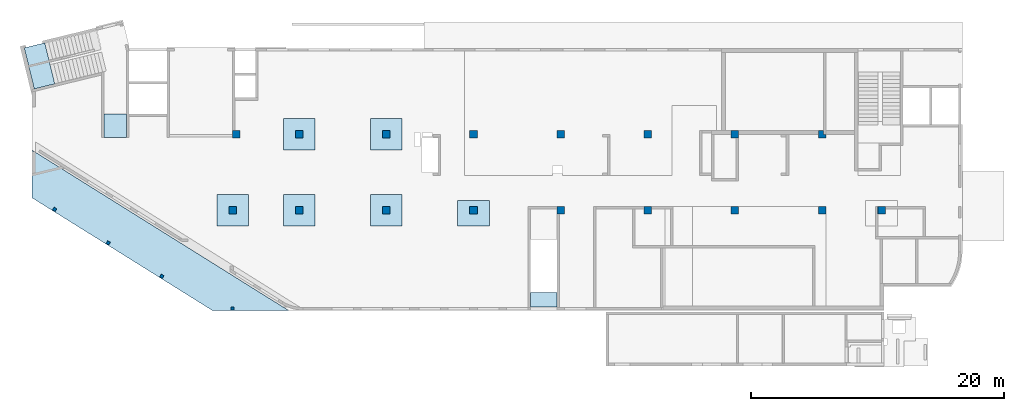
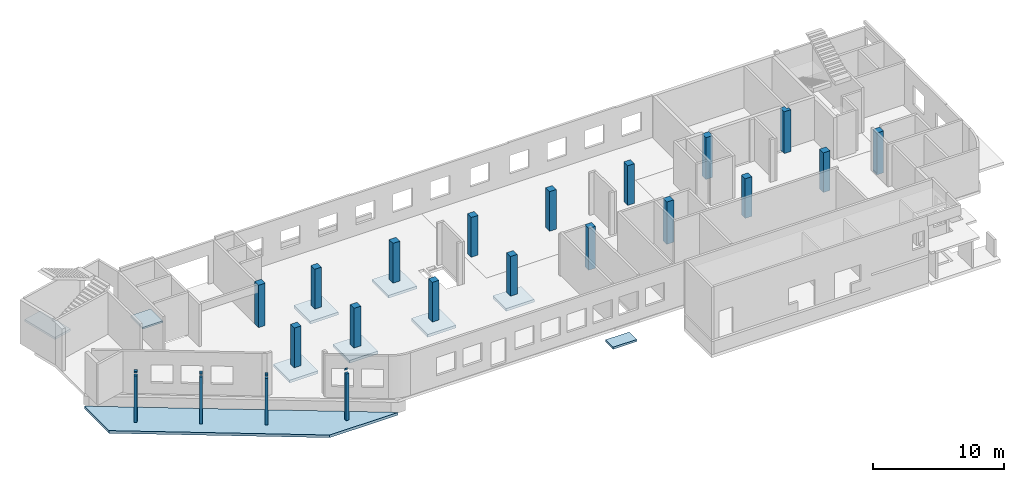
# One storey, part 1 of 8: 21 columns, 10 slabs.
"""IFC4 building model written with IfcOpenShell, lengths in millimetres."""

import ifcopenshell
import ifcopenshell.guid

model = None  # the IFC model being written
_history = None  # IfcOwnerHistory: only IFC2X3 demands one
_inside = {}  # id of a spatial element -> (the spatial element, [elements in it])
_under = {}  # id of a project, library or spatial element -> (it, [spatial elements below it])
_declared = {}  # id of a project -> (the project, [libraries it declares])
_typed = {}  # id of a type object -> (the type object, [elements of that type])
_made_of = {}  # id of a material, layer set ... -> (it, [elements and type objects made of it])


def new_model(schema):
    """Start an empty IFC model of exactly this schema.

    Asked for "IFC4X3", IfcOpenShell would pick the latest addendum, in which some entities
    have other attributes; the version numbers below select the first issue.
    IFC2X3 requires an IfcOwnerHistory on every rooted entity: one is made here for all.
    """
    global model, _history
    if schema == "IFC4X3":
        model = ifcopenshell.file(schema_version=(4, 3, 0, 0))
    else:
        model = ifcopenshell.file(schema=schema)
    _inside.clear()
    _under.clear()
    _declared.clear()
    _typed.clear()
    _made_of.clear()
    _history = None
    if model.schema == "IFC2X3":
        org = make("IfcOrganization", Name="unknown")
        user = make(
            "IfcPersonAndOrganization",
            ThePerson=make("IfcPerson", FamilyName="unknown"),
            TheOrganization=org,
        )
        app = make(
            "IfcApplication",
            ApplicationDeveloper=org,
            Version="unknown",
            ApplicationFullName="unknown",
            ApplicationIdentifier="unknown",
        )
        _history = make(
            "IfcOwnerHistory",
            OwningUser=user,
            OwningApplication=app,
            ChangeAction="ADDED",
            CreationDate=0,
        )
    return model


def make(cls, **values):
    """One entity of the class cls with the attributes given. An attribute that is None is left unset."""
    return model.create_entity(
        cls, **{name: value for name, value in values.items() if value is not None}
    )


def entity(cls, *values):
    """Any entity or typed value of the class cls, its attributes in the order of the schema. None: left unset."""
    e = model.create_entity(cls)
    for i, value in enumerate(values):
        if value is not None:
            e[i] = value
    return e


def rooted(cls, **values):
    """An entity with a GlobalId (a new one), such as an element, a storey or a relation."""
    return make(cls, GlobalId=ifcopenshell.guid.new(), OwnerHistory=_history, **values)


def si_unit(unit_type, name, prefix=None):
    """IfcSIUnit, for example si_unit("LENGTHUNIT", "METRE", prefix="MILLI")."""
    return make("IfcSIUnit", UnitType=unit_type, Prefix=prefix, Name=name)


def converted_unit(unit_type, name, factor, base, dimensions=None, offset=None):
    """IfcConversionBasedUnit, such as the inch: factor (a typed value) times the base unit."""
    return make(
        "IfcConversionBasedUnit"
        if offset is None
        else "IfcConversionBasedUnitWithOffset",
        ConversionOffset=offset,
        Dimensions=None
        if dimensions is None
        else entity("IfcDimensionalExponents", *dimensions),
        UnitType=unit_type,
        Name=name,
        ConversionFactor=make(
            "IfcMeasureWithUnit", ValueComponent=factor, UnitComponent=base
        ),
    )


def derived_unit(unit_type, elements):
    """IfcDerivedUnit: a product of units, each with its exponent."""
    return make(
        "IfcDerivedUnit",
        Elements=[
            make("IfcDerivedUnitElement", Unit=unit, Exponent=power)
            for unit, power in elements
        ],
        UnitType=unit_type,
    )


def assignment(units):
    """IfcUnitAssignment: the units of a project."""
    return None if units is None else make("IfcUnitAssignment", Units=units)


def point(xyz):
    """IfcCartesianPoint."""
    return None if xyz is None else make("IfcCartesianPoint", Coordinates=xyz)


def direction(xyz):
    """IfcDirection."""
    return None if xyz is None else make("IfcDirection", DirectionRatios=xyz)


def frame(location, z_axis=None, x_axis=None):
    """IfcAxis2Placement3D, a coordinate frame: its origin and axes. An axis left out is left unset."""
    return make(
        "IfcAxis2Placement3D",
        Location=point(location),
        Axis=direction(z_axis),
        RefDirection=direction(x_axis),
    )


def origin():
    """The frame at (0, 0, 0) with its axes left unset."""
    return frame((0.0, 0.0, 0.0))


def place(relative_to, where):
    """IfcLocalPlacement: puts the frame where relative to a parent placement (None: the world)."""
    return make(
        "IfcLocalPlacement", PlacementRelTo=relative_to, RelativePlacement=where
    )


def context(
    kind, dimensions, precision=None, world=None, true_north=None, identifier=None
):
    """IfcGeometricRepresentationContext, for example the 3D "Model" context."""
    return make(
        "IfcGeometricRepresentationContext",
        ContextIdentifier=identifier,
        ContextType=kind,
        CoordinateSpaceDimension=dimensions,
        Precision=precision,
        WorldCoordinateSystem=world,
        TrueNorth=true_north,
    )


def subcontext(parent, identifier, kind, view, scale=None):
    """IfcGeometricRepresentationSubContext, for example "Body" below "Model"."""
    return make(
        "IfcGeometricRepresentationSubContext",
        ContextIdentifier=identifier,
        ContextType=kind,
        ParentContext=parent,
        TargetScale=scale,
        TargetView=view,
    )


def project(units=None, contexts=None):
    """IfcProject with its units and contexts."""
    return rooted(
        "IfcProject",
        Name="project",
        RepresentationContexts=contexts,
        UnitsInContext=assignment(units),
    )


def spatial(cls, under=None, at=None, **own):
    """A site, building, storey or space (cls), placed at a placement, below another one or the project."""
    s = rooted(cls, ObjectPlacement=at, **own)
    if under is not None:
        _under.setdefault(under.id(), (under, []))[1].append(s)
    return s


def point_list(points):
    """IfcCartesianPointList2D or 3D."""
    cls = (
        "IfcCartesianPointList2D" if len(points[0]) == 2 else "IfcCartesianPointList3D"
    )
    return make(cls, CoordList=points)


def indexed_curve(points, segments=None, self_intersect=None):
    """IfcIndexedPolyCurve: lines and arcs through numbered points (the first is 1)."""
    return make(
        "IfcIndexedPolyCurve",
        Points=point_list(points),
        Segments=segments,
        SelfIntersect=self_intersect,
    )


def outline(outer, holes=None, kind="AREA"):
    """IfcArbitraryClosedProfileDef: a profile drawn as a closed curve; with holes, ...WithVoids."""
    if holes is None:
        return make("IfcArbitraryClosedProfileDef", ProfileType=kind, OuterCurve=outer)
    return make(
        "IfcArbitraryProfileDefWithVoids",
        ProfileType=kind,
        OuterCurve=outer,
        InnerCurves=holes,
    )


def extrude(swept, where, along, depth):
    """IfcExtrudedAreaSolid: the profile swept, set in the frame where, extruded along a direction by depth."""
    return make(
        "IfcExtrudedAreaSolid",
        SweptArea=swept,
        Position=where,
        ExtrudedDirection=direction(along),
        Depth=depth,
    )


def polygons(points, faces, closed=None, point_numbers=None):
    """IfcPolygonalFaceSet: a face is its outer loop, then its inner loops; points numbered from 1."""
    made = []
    for loops in faces:
        if len(loops) == 1:
            made.append(make("IfcIndexedPolygonalFace", CoordIndex=loops[0]))
        else:
            made.append(
                make(
                    "IfcIndexedPolygonalFaceWithVoids",
                    CoordIndex=loops[0],
                    InnerCoordIndices=loops[1:],
                )
            )
    return make(
        "IfcPolygonalFaceSet",
        Coordinates=point_list(points),
        Closed=closed,
        Faces=made,
        PnIndex=point_numbers,
    )


def shape(context_of_items, identifier, shape_type, items):
    """IfcShapeRepresentation: the items that make up one representation, for example the "Body"."""
    return make(
        "IfcShapeRepresentation",
        ContextOfItems=context_of_items,
        RepresentationIdentifier=identifier,
        RepresentationType=shape_type,
        Items=items,
    )


def source(mapping_origin, context_of_items, identifier, shape_type, items):
    """IfcRepresentationMap: a shape defined once, which mapped items show again and again."""
    return make(
        "IfcRepresentationMap",
        MappingOrigin=mapping_origin,
        MappedRepresentation=shape(context_of_items, identifier, shape_type, items),
    )


def transform(
    local_origin,
    x_axis=None,
    y_axis=None,
    z_axis=None,
    scale=None,
    scale2=None,
    scale3=None,
    uniform=True,
):
    """IfcCartesianTransformationOperator3D, or its non-uniform kind. x_axis, y_axis, z_axis: its Axis1, 2, 3."""
    if uniform:
        return make(
            "IfcCartesianTransformationOperator3D",
            Axis1=direction(x_axis),
            Axis2=direction(y_axis),
            LocalOrigin=point(local_origin),
            Scale=scale,
            Axis3=direction(z_axis),
        )
    return make(
        "IfcCartesianTransformationOperator3DnonUniform",
        Axis1=direction(x_axis),
        Axis2=direction(y_axis),
        LocalOrigin=point(local_origin),
        Scale=scale,
        Axis3=direction(z_axis),
        Scale2=scale2,
        Scale3=scale3,
    )


def mapped(mapping_source, mapping_target):
    """IfcMappedItem: shows the shape of a source again, moved by a transform."""
    return make(
        "IfcMappedItem", MappingSource=mapping_source, MappingTarget=mapping_target
    )


def material(Name=None, Category=None):
    """IfcMaterial."""
    return make("IfcMaterial", Name=Name, Category=Category)


def made_of(thing, what):
    """Note that an element or type object is made of a material, layer set ...; save() writes the relation."""
    if what is not None:
        _made_of.setdefault(what.id(), (what, []))[1].append(thing)
    return thing


def type_object(cls, material=None, **own):
    """A type object (cls), such as IfcWallType, which elements share."""
    return made_of(rooted(cls, **own), material)


def type_shapes(of_type, sources):
    """Give a type object the sources (RepresentationMaps) that its elements show as mapped items."""
    of_type.RepresentationMaps = sources


def element(
    cls,
    number,
    at=None,
    inside=None,
    cuts=None,
    type_object=None,
    material=None,
    context=None,
    identifier="Body",
    shape_type=None,
    held_by="IfcProductDefinitionShape",
    body=None,
    shapes=None,
    **own,
):
    """One element of the class cls, such as IfcWall. Its Tag is "e" and its number.

    at: its placement. inside: the storey or other place that contains it. cuts: it is an
    opening in that element (IfcRelVoidsElement). A single representation is given by context,
    identifier, shape_type and body (its items); several are given by shapes. held_by: the class
    of the entity that holds the representations. save() writes the other relations.
    """
    e = rooted(cls, Tag="e%d" % number, ObjectPlacement=at, **own)
    if body is not None:
        shapes = [shape(context, identifier, shape_type, body)]
    if shapes is not None:
        e.Representation = make(held_by, Representations=shapes)
    if inside is not None:
        _inside.setdefault(inside.id(), (inside, []))[1].append(e)
    if cuts is not None:
        rooted(
            "IfcRelVoidsElement", RelatingBuildingElement=cuts, RelatedOpeningElement=e
        )
    if type_object is not None:
        _typed.setdefault(type_object.id(), (type_object, []))[1].append(e)
    return made_of(e, material)


def aggregate(whole, parts):
    """IfcRelAggregates: a whole, such as a stair, and the parts it consists of."""
    return rooted("IfcRelAggregates", RelatingObject=whole, RelatedObjects=parts)


def save(model, path):
    """Write the relations noted so far, then the file.

    IfcRelAggregates (storeys below a building ...), IfcRelContainedInSpatialStructure (elements
    in a storey), IfcRelDefinesByType, IfcRelAssociatesMaterial and IfcRelDeclares: one each for
    every whole, place, type object, material and project.
    """
    for whole, parts in _under.values():
        aggregate(whole, parts)
    for where, things in _inside.values():
        rooted(
            "IfcRelContainedInSpatialStructure",
            RelatedElements=things,
            RelatingStructure=where,
        )
    for kind, things in _typed.values():
        rooted("IfcRelDefinesByType", RelatedObjects=things, RelatingType=kind)
    for what, things in _made_of.values():
        rooted("IfcRelAssociatesMaterial", RelatedObjects=things, RelatingMaterial=what)
    for by, libraries in _declared.values():
        rooted("IfcRelDeclares", RelatingContext=by, RelatedDefinitions=libraries)
    model.write(path)


model = new_model("IFC4")

# Units and contexts
model_context = context("Model", 3, precision=0.01, world=origin(), true_north=direction((6.12303176911189e-17, 1.0)))
plan_context = context("Plan", 3, precision=0.01, world=origin(), true_north=direction((6.12303176911189e-17, 1.0)))
body_context = subcontext(model_context, "Body", "Model", "MODEL_VIEW")
ifc_project = project(units=[si_unit("LENGTHUNIT", "METRE", prefix="MILLI"), si_unit("AREAUNIT", "SQUARE_METRE"), si_unit("VOLUMEUNIT", "CUBIC_METRE"), converted_unit("PLANEANGLEUNIT", "DEGREE", entity("IfcRatioMeasure", 0.0174532925199433), si_unit("PLANEANGLEUNIT", "RADIAN"), dimensions=[0, 0, 0, 0, 0, 0, 0]), si_unit("MASSUNIT", "GRAM", prefix="KILO"), derived_unit("MASSDENSITYUNIT", [(si_unit("MASSUNIT", "GRAM", prefix="KILO"), 1), (si_unit("LENGTHUNIT", "METRE"), -3)]), derived_unit("MOMENTOFINERTIAUNIT", [(si_unit("LENGTHUNIT", "METRE"), 4)]), si_unit("TIMEUNIT", "SECOND"), si_unit("FREQUENCYUNIT", "HERTZ"), si_unit("THERMODYNAMICTEMPERATUREUNIT", "DEGREE_CELSIUS"), derived_unit("THERMALTRANSMITTANCEUNIT", [(si_unit("MASSUNIT", "GRAM", prefix="KILO"), 1), (si_unit("THERMODYNAMICTEMPERATUREUNIT", "KELVIN"), -1), (si_unit("TIMEUNIT", "SECOND"), -3)]), derived_unit("VOLUMETRICFLOWRATEUNIT", [(si_unit("LENGTHUNIT", "METRE"), 3), (si_unit("TIMEUNIT", "SECOND"), -1)]), derived_unit("MASSFLOWRATEUNIT", [(si_unit("MASSUNIT", "GRAM", prefix="KILO"), 1), (si_unit("TIMEUNIT", "SECOND"), -1)]), derived_unit("ROTATIONALFREQUENCYUNIT", [(si_unit("TIMEUNIT", "SECOND"), -1)]), si_unit("ELECTRICCURRENTUNIT", "AMPERE"), si_unit("ELECTRICVOLTAGEUNIT", "VOLT"), si_unit("POWERUNIT", "WATT"), si_unit("FORCEUNIT", "NEWTON", prefix="KILO"), si_unit("ILLUMINANCEUNIT", "LUX"), si_unit("LUMINOUSFLUXUNIT", "LUMEN"), si_unit("LUMINOUSINTENSITYUNIT", "CANDELA"), derived_unit("USERDEFINED", [(si_unit("MASSUNIT", "GRAM", prefix="KILO"), -1), (si_unit("LENGTHUNIT", "METRE"), -2), (si_unit("TIMEUNIT", "SECOND"), 3), (si_unit("LUMINOUSFLUXUNIT", "LUMEN"), 1)]), derived_unit("LINEARVELOCITYUNIT", [(si_unit("LENGTHUNIT", "METRE"), 1), (si_unit("TIMEUNIT", "SECOND"), -1)]), si_unit("PRESSUREUNIT", "PASCAL"), derived_unit("USERDEFINED", [(si_unit("LENGTHUNIT", "METRE"), -2), (si_unit("MASSUNIT", "GRAM", prefix="KILO"), 1), (si_unit("TIMEUNIT", "SECOND"), -2)]), derived_unit("LINEARFORCEUNIT", [(si_unit("MASSUNIT", "GRAM", prefix="KILO"), 1), (si_unit("LENGTHUNIT", "METRE"), 1), (si_unit("TIMEUNIT", "SECOND"), -2), (si_unit("LENGTHUNIT", "METRE"), -1)]), derived_unit("PLANARFORCEUNIT", [(si_unit("MASSUNIT", "GRAM", prefix="KILO"), 1), (si_unit("LENGTHUNIT", "METRE"), 1), (si_unit("TIMEUNIT", "SECOND"), -2), (si_unit("LENGTHUNIT", "METRE"), -2)])], contexts=[model_context, plan_context])

# Site, building, storey
site_placement = place(None, origin())
site = spatial("IfcSite", under=ifc_project, at=site_placement, CompositionType="ELEMENT")
building_placement = place(site_placement, origin())
building = spatial("IfcBuilding", under=site, at=building_placement, CompositionType="ELEMENT")
storey_placement = place(building_placement, origin())
storey = spatial("IfcBuildingStorey", under=building, at=storey_placement, CompositionType="ELEMENT", Elevation=0.0)

# Columns
ifc_material = material()
column_type_1 = type_object("IfcColumnType", PredefinedType="COLUMN", material=ifc_material)
shared_shape_1 = source(origin(), body_context, "Body", "SweptSolid", [
    extrude(outline(indexed_curve([(-300.0, -300.000000000001), (300.0, -300.000000000001), (300.0, 299.999999999999), (-300.0, 299.999999999999), (-300.0, -300.000000000001)], self_intersect=False)), frame((15900.0002685547, 7699.99922635634, -150.0), z_axis=(0.0, 0.0, 1.0), x_axis=(0.0, -1.0, 0.0)), (0.0, 0.0, 1.0), 3700.0),
])
type_shapes(column_type_1, [shared_shape_1])
column_1_placement = place(storey_placement, origin())
element("IfcColumn", 1, at=column_1_placement, inside=storey, type_object=column_type_1, PredefinedType="COLUMN", context=body_context, shape_type="MappedRepresentation", body=[
    mapped(shared_shape_1, transform((0.0, 0.0, 0.0), scale=1.0)),
])
column_type_2 = type_object("IfcColumnType", PredefinedType="COLUMN", material=ifc_material)
shared_shape_2 = source(origin(), body_context, "Body", "SweptSolid", [
    extrude(outline(indexed_curve([(-300.0, -300.000000000001), (300.0, -300.000000000001), (300.0, 299.999999999997), (-300.0, 300.000000000001), (-300.0, -300.000000000001)], self_intersect=False)), frame((21170.0002685546, 7699.99922635633, -150.0), z_axis=(0.0, 0.0, 1.0), x_axis=(0.0, -1.0, 0.0)), (0.0, 0.0, 1.0), 3700.0),
])
type_shapes(column_type_2, [shared_shape_2])
column_2_placement = place(storey_placement, origin())
element("IfcColumn", 2, at=column_2_placement, inside=storey, type_object=column_type_2, PredefinedType="COLUMN", context=body_context, shape_type="MappedRepresentation", body=[
    mapped(shared_shape_2, transform((0.0, 0.0, 0.0), scale=1.0)),
])
column_type_3 = type_object("IfcColumnType", PredefinedType="COLUMN", material=ifc_material)
shared_shape_3 = source(origin(), body_context, "Body", "SweptSolid", [
    extrude(outline(indexed_curve([(-300.0, -300.000000000001), (300.0, -300.000000000001), (300.0, 299.999999999997), (-300.0, 300.000000000001), (-300.0, -300.000000000001)], self_intersect=False)), frame((28070.0002685546, 7699.9992263563, -150.0), z_axis=(0.0, 0.0, 1.0), x_axis=(0.0, -1.0, 0.0)), (0.0, 0.0, 1.0), 3700.0),
])
type_shapes(column_type_3, [shared_shape_3])
column_3_placement = place(storey_placement, origin())
element("IfcColumn", 3, at=column_3_placement, inside=storey, type_object=column_type_3, PredefinedType="COLUMN", context=body_context, shape_type="MappedRepresentation", body=[
    mapped(shared_shape_3, transform((0.0, 0.0, 0.0), scale=1.0)),
])
column_type_4 = type_object("IfcColumnType", PredefinedType="COLUMN", material=ifc_material)
shared_shape_4 = source(origin(), body_context, "Body", "SweptSolid", [
    extrude(outline(indexed_curve([(-300.000000000001, -300.000000000001), (299.999999999999, -300.000000000001), (299.999999999999, 299.999999999997), (-300.000000000001, 300.000000000001), (-300.000000000001, -300.000000000001)], self_intersect=False)), frame((34970.0002685546, 7699.99922635628, -150.0), z_axis=(0.0, 0.0, 1.0), x_axis=(0.0, -1.0, 0.0)), (0.0, 0.0, 1.0), 3700.0),
])
type_shapes(column_type_4, [shared_shape_4])
column_4_placement = place(storey_placement, origin())
element("IfcColumn", 4, at=column_4_placement, inside=storey, type_object=column_type_4, PredefinedType="COLUMN", context=body_context, shape_type="MappedRepresentation", body=[
    mapped(shared_shape_4, transform((0.0, 0.0, 0.0), scale=1.0)),
])
column_type_5 = type_object("IfcColumnType", PredefinedType="COLUMN", material=ifc_material)
shared_shape_5 = source(origin(), body_context, "Body", "SweptSolid", [
    extrude(outline(indexed_curve([(-300.0, -300.000000000001), (300.0, -300.000000000001), (300.0, 300.000000000001), (-300.0, 300.000000000001), (-300.0, -300.000000000001)], self_intersect=False)), frame((41870.0002685547, 7699.99922635626, -150.0), z_axis=(0.0, 0.0, 1.0), x_axis=(0.0, -1.0, 0.0)), (0.0, 0.0, 1.0), 3900.0),
])
type_shapes(column_type_5, [shared_shape_5])
column_5_placement = place(storey_placement, origin())
element("IfcColumn", 5, at=column_5_placement, inside=storey, type_object=column_type_5, PredefinedType="COLUMN", context=body_context, shape_type="MappedRepresentation", body=[
    mapped(shared_shape_5, transform((0.0, 0.0, 0.0), scale=1.0)),
])
column_type_6 = type_object("IfcColumnType", PredefinedType="COLUMN", material=ifc_material)
shared_shape_6 = source(origin(), body_context, "Body", "SweptSolid", [
    extrude(outline(indexed_curve([(-300.0, -300.000000000001), (300.0, -300.000000000001), (300.0, 300.000000000001), (-300.0, 300.000000000001), (-300.0, -300.000000000001)], self_intersect=False)), frame((48770.0002685546, 7699.99922635624, -150.0), z_axis=(0.0, 0.0, 1.0), x_axis=(0.0, -1.0, 0.0)), (0.0, 0.0, 1.0), 3950.0),
])
type_shapes(column_type_6, [shared_shape_6])
column_6_placement = place(storey_placement, origin())
element("IfcColumn", 6, at=column_6_placement, inside=storey, type_object=column_type_6, PredefinedType="COLUMN", context=body_context, shape_type="MappedRepresentation", body=[
    mapped(shared_shape_6, transform((0.0, 0.0, 0.0), scale=1.0)),
])
column_type_7 = type_object("IfcColumnType", PredefinedType="COLUMN", material=ifc_material)
shared_shape_7 = source(origin(), body_context, "Body", "SweptSolid", [
    extrude(outline(indexed_curve([(-300.0, -300.000000000001), (300.0, -300.000000000001), (300.0, 300.000000000001), (-300.0, 300.000000000001), (-300.0, -300.000000000001)], self_intersect=False)), frame((55670.0002685547, 7699.99922635621, -150.0), z_axis=(0.0, 0.0, 1.0), x_axis=(0.0, -1.0, 0.0)), (0.0, 0.0, 1.0), 3700.0),
])
type_shapes(column_type_7, [shared_shape_7])
column_7_placement = place(storey_placement, origin())
element("IfcColumn", 7, at=column_7_placement, inside=storey, type_object=column_type_7, PredefinedType="COLUMN", context=body_context, shape_type="MappedRepresentation", body=[
    mapped(shared_shape_7, transform((0.0, 0.0, 0.0), scale=1.0)),
])
column_type_8 = type_object("IfcColumnType", PredefinedType="COLUMN", material=ifc_material)
shared_shape_8 = source(origin(), body_context, "Body", "SweptSolid", [
    extrude(outline(indexed_curve([(-299.999999999999, -300.000000000001), (300.000000000001, -300.000000000001), (300.000000000001, 300.000000000001), (-299.999999999999, 300.000000000001), (-299.999999999999, -300.000000000001)], self_intersect=False)), frame((62570.0002685546, 7699.99922635619, -150.0), z_axis=(0.0, 0.0, 1.0), x_axis=(0.0, -1.0, 0.0)), (0.0, 0.0, 1.0), 3700.0),
])
type_shapes(column_type_8, [shared_shape_8])
column_8_placement = place(storey_placement, origin())
element("IfcColumn", 8, at=column_8_placement, inside=storey, type_object=column_type_8, PredefinedType="COLUMN", context=body_context, shape_type="MappedRepresentation", body=[
    mapped(shared_shape_8, transform((0.0, 0.0, 0.0), scale=1.0)),
])
column_type_9 = type_object("IfcColumnType", PredefinedType="COLUMN", material=ifc_material)
shared_shape_9 = source(origin(), body_context, "Body", "Tessellation", [
    polygons([(600.000000000002, 600.0, 0.0), (600.000000000002, 1.08286712929839e-12, 0.0), (0.0, 1.08286712929839e-12, 0.0), (0.0, 600.0, 0.0), (600.000000000002, 600.0, 150.0), (600.000000000002, 600.0, 3900.0), (600.000000000002, 1.08286712929839e-12, 3900.0), (24.9997314451952, 1.08286712929839e-12, 3900.0), (24.9997314451952, 1.08286712929839e-12, 150.0), (0.0, 1.08286712929839e-12, 150.0), (0.0, 600.0, 150.0), (24.9997314451952, 600.0, 150.0), (24.9997314451952, 600.0, 3900.0)], [[[1, 2, 3, 4]], [[2, 1, 5, 6, 7]], [[3, 2, 7, 8, 9, 10]], [[4, 3, 10, 11]], [[1, 4, 11, 12, 13, 6, 5]], [[7, 6, 13, 8]], [[12, 9, 8, 13]], [[9, 12, 11, 10]]], closed=True),
])
type_shapes(column_type_9, [shared_shape_9])
column_9_placement = place(storey_placement, frame((66970.0002685546, 7399.99922635617, -150.0)))
element("IfcColumn", 9, at=column_9_placement, inside=storey, type_object=column_type_9, material=ifc_material, PredefinedType="COLUMN", context=body_context, shape_type="MappedRepresentation", body=[
    mapped(shared_shape_9, transform((0.0, 0.0, 0.0), scale=1.0)),
])
column_type_10 = type_object("IfcColumnType", PredefinedType="COLUMN", material=ifc_material)
shared_shape_10 = source(origin(), body_context, "Body", "SweptSolid", [
    extrude(outline(indexed_curve([(-299.999999999999, -333.333333333327), (300.000000000001, -333.333333333327), (299.999999999999, 266.666666666675), (-4.33146851719357e-12, 266.666666666675), (-2.16573425859679e-12, 66.6666666666688), (-299.999999999999, 66.6666666666688), (-299.999999999999, -333.333333333327)], self_intersect=False)), frame((62603.333601888, 13699.9992263562, -150.0), z_axis=(0.0, 0.0, 1.0), x_axis=(0.0, -1.0, 0.0)), (0.0, 0.0, 1.0), 3900.0),
])
type_shapes(column_type_10, [shared_shape_10])
column_10_placement = place(storey_placement, origin())
element("IfcColumn", 10, at=column_10_placement, inside=storey, type_object=column_type_10, PredefinedType="COLUMN", context=body_context, shape_type="MappedRepresentation", body=[
    mapped(shared_shape_10, transform((0.0, 0.0, 0.0), scale=1.0)),
])
column_type_11 = type_object("IfcColumnType", PredefinedType="COLUMN", material=ifc_material)
shared_shape_11 = source(origin(), body_context, "Body", "SweptSolid", [
    extrude(outline(indexed_curve([(-299.999999999997, -300.000000000001), (300.000000000003, -300.000000000001), (300.000000000001, 300.000000000001), (-299.999999999999, 300.000000000001), (-299.999999999997, -300.000000000001)], self_intersect=False)), frame((55670.0002685547, 13699.9992263562, -150.0), z_axis=(0.0, 0.0, 1.0), x_axis=(0.0, -1.0, 0.0)), (0.0, 0.0, 1.0), 3900.0),
])
type_shapes(column_type_11, [shared_shape_11])
column_11_placement = place(storey_placement, origin())
element("IfcColumn", 11, at=column_11_placement, inside=storey, type_object=column_type_11, PredefinedType="COLUMN", context=body_context, shape_type="MappedRepresentation", body=[
    mapped(shared_shape_11, transform((0.0, 0.0, 0.0), scale=1.0)),
])
column_type_12 = type_object("IfcColumnType", PredefinedType="COLUMN", material=ifc_material)
shared_shape_12 = source(origin(), body_context, "Body", "SweptSolid", [
    extrude(outline(indexed_curve([(-299.999999999999, -300.000000000001), (300.000000000001, -300.000000000001), (299.999999999999, 300.000000000001), (-300.000000000001, 300.000000000001), (-299.999999999999, -300.000000000001)], self_intersect=False)), frame((48770.0002685547, 13699.9992263562, -150.0), z_axis=(0.0, 0.0, 1.0), x_axis=(0.0, -1.0, 0.0)), (0.0, 0.0, 1.0), 3700.0),
])
type_shapes(column_type_12, [shared_shape_12])
column_12_placement = place(storey_placement, origin())
element("IfcColumn", 12, at=column_12_placement, inside=storey, type_object=column_type_12, PredefinedType="COLUMN", context=body_context, shape_type="MappedRepresentation", body=[
    mapped(shared_shape_12, transform((0.0, 0.0, 0.0), scale=1.0)),
])
column_type_13 = type_object("IfcColumnType", PredefinedType="COLUMN", material=ifc_material)
shared_shape_13 = source(origin(), body_context, "Body", "SweptSolid", [
    extrude(outline(indexed_curve([(-300.000000000001, -300.000000000001), (299.999999999999, -300.000000000001), (299.999999999997, 300.000000000001), (-300.000000000003, 300.000000000001), (-300.000000000001, -300.000000000001)], self_intersect=False)), frame((41870.0002685547, 13699.9992263563, -150.0), z_axis=(0.0, 0.0, 1.0), x_axis=(0.0, -1.0, 0.0)), (0.0, 0.0, 1.0), 3700.0),
])
type_shapes(column_type_13, [shared_shape_13])
column_13_placement = place(storey_placement, origin())
element("IfcColumn", 13, at=column_13_placement, inside=storey, type_object=column_type_13, PredefinedType="COLUMN", context=body_context, shape_type="MappedRepresentation", body=[
    mapped(shared_shape_13, transform((0.0, 0.0, 0.0), scale=1.0)),
])
column_type_14 = type_object("IfcColumnType", PredefinedType="COLUMN", material=ifc_material)
shared_shape_14 = source(origin(), body_context, "Body", "SweptSolid", [
    extrude(outline(indexed_curve([(-299.999999999999, -300.000000000001), (300.000000000001, -300.000000000001), (299.999999999999, 299.999999999997), (-300.000000000001, 300.000000000001), (-299.999999999999, -300.000000000001)], self_intersect=False)), frame((34970.0002685546, 13699.9992263563, -150.0), z_axis=(0.0, 0.0, 1.0), x_axis=(0.0, -1.0, 0.0)), (0.0, 0.0, 1.0), 3700.0),
])
type_shapes(column_type_14, [shared_shape_14])
column_14_placement = place(storey_placement, origin())
element("IfcColumn", 14, at=column_14_placement, inside=storey, type_object=column_type_14, PredefinedType="COLUMN", context=body_context, shape_type="MappedRepresentation", body=[
    mapped(shared_shape_14, transform((0.0, 0.0, 0.0), scale=1.0)),
])
column_type_15 = type_object("IfcColumnType", PredefinedType="COLUMN", material=ifc_material)
shared_shape_15 = source(origin(), body_context, "Body", "SweptSolid", [
    extrude(outline(indexed_curve([(-299.999999999997, -300.000000000001), (300.000000000003, -300.000000000001), (300.000000000001, 299.999999999997), (-299.999999999999, 300.000000000001), (-299.999999999997, -300.000000000001)], self_intersect=False)), frame((28070.0002685547, 13699.9992263563, -150.0), z_axis=(0.0, 0.0, 1.0), x_axis=(0.0, -1.0, 0.0)), (0.0, 0.0, 1.0), 3700.0),
])
type_shapes(column_type_15, [shared_shape_15])
column_15_placement = place(storey_placement, origin())
element("IfcColumn", 15, at=column_15_placement, inside=storey, type_object=column_type_15, PredefinedType="COLUMN", context=body_context, shape_type="MappedRepresentation", body=[
    mapped(shared_shape_15, transform((0.0, 0.0, 0.0), scale=1.0)),
])
column_type_16 = type_object("IfcColumnType", PredefinedType="COLUMN", material=ifc_material)
shared_shape_16 = source(origin(), body_context, "Body", "SweptSolid", [
    extrude(outline(indexed_curve([(-299.999999999999, -300.000000000001), (300.000000000001, -300.000000000001), (299.999999999999, 299.999999999997), (-300.000000000001, 300.000000000001), (-299.999999999999, -300.000000000001)], self_intersect=False)), frame((21170.0002685547, 13699.9992263563, -150.0), z_axis=(0.0, 0.0, 1.0), x_axis=(0.0, -1.0, 0.0)), (0.0, 0.0, 1.0), 3700.0),
])
type_shapes(column_type_16, [shared_shape_16])
column_16_placement = place(storey_placement, origin())
element("IfcColumn", 16, at=column_16_placement, inside=storey, type_object=column_type_16, PredefinedType="COLUMN", context=body_context, shape_type="MappedRepresentation", body=[
    mapped(shared_shape_16, transform((0.0, 0.0, 0.0), scale=1.0)),
])
column_type_17 = type_object("IfcColumnType", PredefinedType="COLUMN", material=ifc_material)
shared_shape_17 = source(origin(), body_context, "Body", "SweptSolid", [
    extrude(outline(indexed_curve([(-300.000000000001, -300.000000000001), (299.999999999999, -300.000000000001), (299.999999999999, 299.999999999999), (-300.000000000001, 299.999999999999), (-300.000000000001, -300.000000000001)], self_intersect=False)), frame((16200.0002685547, 13699.9992263563, -150.0), z_axis=(0.0, 0.0, 1.0), x_axis=(0.0, -1.0, 0.0)), (0.0, 0.0, 1.0), 3950.0),
])
type_shapes(column_type_17, [shared_shape_17])
column_17_placement = place(storey_placement, origin())
element("IfcColumn", 17, at=column_17_placement, inside=storey, type_object=column_type_17, PredefinedType="COLUMN", context=body_context, shape_type="MappedRepresentation", body=[
    mapped(shared_shape_17, transform((0.0, 0.0, 0.0), scale=1.0)),
])
column_type_18 = type_object("IfcColumnType", PredefinedType="COLUMN", material=ifc_material)
shared_shape_18 = source(origin(), body_context, "Body", "SweptSolid", [
    extrude(outline(indexed_curve([(-125.0, -125.0), (125.0, -125.0), (125.0, 125.0), (-125.0, 125.0), (-125.0, -125.0)], self_intersect=False)), frame((15900.0002685546, -75.0007736436563, -550.0), z_axis=(0.0, 0.0, 1.0), x_axis=(0.0, -1.0, 0.0)), (0.0, 0.0, 1.0), 4350.0),
    extrude(outline(indexed_curve([(-25.0000000000073, -125.0), (25.000000000007, -125.0), (25.0000000000077, 125.0), (-25.0000000000073, 125.0), (-25.0000000000073, -125.0)], self_intersect=False)), frame((15900.0002685546, 24.9992263563364, 4050.0), z_axis=(0.0, 0.0, 1.0), x_axis=(0.0, -1.0, 0.0)), (0.0, 0.0, 1.0), 150.0),
])
type_shapes(column_type_18, [shared_shape_18])
column_18_placement = place(storey_placement, origin())
element("IfcColumn", 18, at=column_18_placement, inside=storey, type_object=column_type_18, PredefinedType="COLUMN", context=body_context, shape_type="MappedRepresentation", body=[
    mapped(shared_shape_18, transform((0.0, 0.0, 0.0), scale=1.0)),
])
column_type_19 = type_object("IfcColumnType", PredefinedType="COLUMN", material=ifc_material)
shared_shape_19 = source(origin(), body_context, "Body", "SweptSolid", [
    extrude(outline(indexed_curve([(-125.0, -125.0), (125.0, -125.0), (125.0, 125.0), (-125.0, 125.0), (-125.0, -125.0)], self_intersect=False)), frame((10294.0765822688, 2463.18169635146, -550.0), z_axis=(0.0, 0.0, 1.0), x_axis=(-0.84805274377757, 0.529911826412031, 0.0)), (0.0, 0.0, 1.0), 4350.0),
    extrude(outline(indexed_curve([(-125.0, -125.0), (125.0, -125.0), (125.0, 125.0), (-125.0, 125.0), (-125.0, -125.0)], self_intersect=False)), frame((10294.0765822688, 2463.18169635146, 4050.0), z_axis=(0.0, 0.0, 1.0), x_axis=(-0.84805274377757, 0.529911826412031, 0.0)), (0.0, 0.0, 1.0), 150.0),
])
type_shapes(column_type_19, [shared_shape_19])
column_19_placement = place(storey_placement, origin())
element("IfcColumn", 19, at=column_19_placement, inside=storey, type_object=column_type_19, PredefinedType="COLUMN", context=body_context, shape_type="MappedRepresentation", body=[
    mapped(shared_shape_19, transform((0.0, 0.0, 0.0), scale=1.0)),
])
column_type_20 = type_object("IfcColumnType", PredefinedType="COLUMN", material=ifc_material)
shared_shape_20 = source(origin(), body_context, "Body", "SweptSolid", [
    extrude(outline(indexed_curve([(-125.0, -125.0), (125.0, -125.0), (125.0, 125.0), (-125.0, 125.0), (-125.0, -125.0)], self_intersect=False)), frame((6053.81286338096, 5112.7408284116, -550.0), z_axis=(0.0, 0.0, 1.0), x_axis=(-0.848052743777571, 0.52991182641203, 0.0)), (0.0, 0.0, 1.0), 4350.0),
    extrude(outline(indexed_curve([(-125.0, -125.0), (125.0, -125.0), (125.0, 125.0), (-125.0, 125.0), (-125.0, -125.0)], self_intersect=False)), frame((6053.81286338096, 5112.7408284116, 4050.0), z_axis=(0.0, 0.0, 1.0), x_axis=(-0.848052743777571, 0.52991182641203, 0.0)), (0.0, 0.0, 1.0), 150.0),
])
type_shapes(column_type_20, [shared_shape_20])
column_20_placement = place(storey_placement, origin())
element("IfcColumn", 20, at=column_20_placement, inside=storey, type_object=column_type_20, PredefinedType="COLUMN", context=body_context, shape_type="MappedRepresentation", body=[
    mapped(shared_shape_20, transform((0.0, 0.0, 0.0), scale=1.0)),
])
column_type_21 = type_object("IfcColumnType", PredefinedType="COLUMN", material=ifc_material)
shared_shape_21 = source(origin(), body_context, "Body", "SweptSolid", [
    extrude(outline(indexed_curve([(-125.0, -125.0), (125.0, -125.0), (125.0, 125.0), (-125.0, 125.000000000001), (-125.0, -125.0)], self_intersect=False)), frame((1813.54914449309, 7762.29996047173, -550.0), z_axis=(0.0, 0.0, 1.0), x_axis=(-0.848052743777571, 0.52991182641203, 0.0)), (0.0, 0.0, 1.0), 4350.0),
    extrude(outline(indexed_curve([(-125.0, -125.0), (125.0, -125.0), (125.0, 125.0), (-125.0, 125.000000000001), (-125.0, -125.0)], self_intersect=False)), frame((1813.54914449309, 7762.29996047173, 4050.0), z_axis=(0.0, 0.0, 1.0), x_axis=(-0.848052743777571, 0.52991182641203, 0.0)), (0.0, 0.0, 1.0), 150.0),
])
type_shapes(column_type_21, [shared_shape_21])
column_21_placement = place(storey_placement, origin())
element("IfcColumn", 21, at=column_21_placement, inside=storey, type_object=column_type_21, PredefinedType="COLUMN", context=body_context, shape_type="MappedRepresentation", body=[
    mapped(shared_shape_21, transform((0.0, 0.0, 0.0), scale=1.0)),
])

# Slabs
slab_type_1 = type_object("IfcSlabType", PredefinedType="FLOOR", material=ifc_material)
slab_1_placement = place(storey_placement, origin())
element("IfcSlab", 22, at=slab_1_placement, inside=storey, type_object=slab_type_1, material=ifc_material, PredefinedType="FLOOR", context=body_context, shape_type="SweptSolid", body=[
    extrude(outline(indexed_curve([(3526.23976666387, -8662.64363341016), (7299.58997805036, -8662.64363341016), (-5412.91487235712, 11682.0138762549), (-5412.91487235712, 5643.27339056538), (3526.23976666387, -8662.64363341016)], self_intersect=False)), frame((8662.6439019648, 5162.9140987133, -1320.0), z_axis=(0.0, 0.0, -1.0), x_axis=(0.0, 1.0, 0.0)), (0.0, 0.0, 1.0), 250.0),
])
slab_type_2 = type_object("IfcSlabType", PredefinedType="FLOOR", material=ifc_material)
slab_2_placement = place(storey_placement, origin())
element("IfcSlab", 23, at=slab_2_placement, inside=storey, type_object=slab_type_2, material=ifc_material, PredefinedType="FLOOR", context=body_context, shape_type="SweptSolid", body=[
    extrude(outline(indexed_curve([(-1250.0, -1250.0), (1250.0, -1250.0), (1250.0, 1250.0), (-1250.0, 1250.0), (-1250.0, -1250.0)], self_intersect=False)), frame((15900.0002685547, 7699.99922635634, -400.0), z_axis=(0.0, 0.0, -1.0), x_axis=(0.0, 1.0, 0.0)), (0.0, 0.0, 1.0), 250.0),
])
slab_type_3 = type_object("IfcSlabType", PredefinedType="FLOOR", material=ifc_material)
slab_3_placement = place(storey_placement, origin())
element("IfcSlab", 24, at=slab_3_placement, inside=storey, type_object=slab_type_3, material=ifc_material, PredefinedType="FLOOR", context=body_context, shape_type="SweptSolid", body=[
    extrude(outline(indexed_curve([(-1250.0, -1250.0), (1250.0, -1250.0), (1250.0, 1250.00000000001), (-1250.0, 1250.0), (-1250.0, -1250.0)], self_intersect=False)), frame((21170.0002685546, 7699.99922635633, -400.0), z_axis=(0.0, 0.0, -1.0), x_axis=(0.0, 1.0, 0.0)), (0.0, 0.0, 1.0), 250.0),
])
slab_type_4 = type_object("IfcSlabType", PredefinedType="FLOOR", material=ifc_material)
slab_4_placement = place(storey_placement, origin())
element("IfcSlab", 25, at=slab_4_placement, inside=storey, type_object=slab_type_4, material=ifc_material, PredefinedType="FLOOR", context=body_context, shape_type="SweptSolid", body=[
    extrude(outline(indexed_curve([(-1250.0, -1250.0), (1250.0, -1250.0), (1250.0, 1250.00000000001), (-1250.0, 1250.0), (-1250.0, -1250.0)], self_intersect=False)), frame((28070.0002685546, 7699.9992263563, -400.0), z_axis=(0.0, 0.0, -1.0), x_axis=(0.0, 1.0, 0.0)), (0.0, 0.0, 1.0), 250.0),
])
slab_type_5 = type_object("IfcSlabType", PredefinedType="FLOOR", material=ifc_material)
slab_5_placement = place(storey_placement, origin())
element("IfcSlab", 26, at=slab_5_placement, inside=storey, type_object=slab_type_5, material=ifc_material, PredefinedType="FLOOR", context=body_context, shape_type="SweptSolid", body=[
    extrude(outline(indexed_curve([(-999.999999999959, -1250.0), (999.99999999996, -1250.0), (999.99999999996, 1250.00000000001), (-999.999999999959, 1250.0), (-999.999999999959, -1250.0)], self_intersect=False)), frame((34970.0002685546, 7449.99922635624, -400.0), z_axis=(0.0, 0.0, -1.0), x_axis=(0.0, 1.0, 0.0)), (0.0, 0.0, 1.0), 250.0),
])
slab_type_6 = type_object("IfcSlabType", PredefinedType="FLOOR", material=ifc_material)
slab_6_placement = place(storey_placement, origin())
element("IfcSlab", 27, at=slab_6_placement, inside=storey, type_object=slab_type_6, material=ifc_material, PredefinedType="FLOOR", context=body_context, shape_type="SweptSolid", body=[
    extrude(outline(indexed_curve([(-1250.0, -1250.0), (1250.0, -1250.0), (1250.0, 1250.00000000001), (-1250.0, 1250.0), (-1250.0, -1250.0)], self_intersect=False)), frame((21170.0002685547, 13699.9992263564, -400.0), z_axis=(0.0, 0.0, -1.0), x_axis=(0.0, 1.0, 0.0)), (0.0, 0.0, 1.0), 250.0),
])
slab_type_7 = type_object("IfcSlabType", PredefinedType="FLOOR", material=ifc_material)
slab_7_placement = place(storey_placement, origin())
element("IfcSlab", 28, at=slab_7_placement, inside=storey, type_object=slab_type_7, material=ifc_material, PredefinedType="FLOOR", context=body_context, shape_type="SweptSolid", body=[
    extrude(outline(indexed_curve([(-1250.0, -1250.0), (1250.0, -1250.0), (1250.0, 1250.00000000001), (-1250.0, 1250.0), (-1250.0, -1250.0)], self_intersect=False)), frame((28070.0002685547, 13699.9992263564, -400.0), z_axis=(0.0, 0.0, -1.0), x_axis=(0.0, 1.0, 0.0)), (0.0, 0.0, 1.0), 250.0),
])
slab_type_8 = type_object("IfcSlabType", PredefinedType="FLOOR", material=ifc_material)
slab_8_placement = place(storey_placement, origin())
element("IfcSlab", 29, at=slab_8_placement, inside=storey, type_object=slab_type_8, material=ifc_material, PredefinedType="FLOOR", context=body_context, shape_type="SweptSolid", body=[
    extrude(outline(indexed_curve([(-925.000000000002, -900.000000000003), (924.999999999998, -900.000000000003), (924.999999999998, 900.000000000002), (-925.000000000002, 900.000000000002), (-925.000000000002, -900.000000000003)], self_intersect=False)), frame((6600.00026855468, 14374.9992263564, 3400.0), z_axis=(0.0, 0.0, -1.0), x_axis=(0.0, 1.0, 0.0)), (0.0, 0.0, 1.0), 150.0),
])
slab_type_9 = type_object("IfcSlabType", PredefinedType="FLOOR", material=ifc_material)
slab_9_placement = place(storey_placement, origin())
element("IfcSlab", 30, at=slab_9_placement, inside=storey, type_object=slab_type_9, material=ifc_material, PredefinedType="FLOOR", context=body_context, shape_type="SweptSolid", body=[
    extrude(outline(indexed_curve([(-835.0, -1670.00000000002), (835.0, -1670.00000000002), (834.999999999999, 1670.00000000002), (-835.000000000001, 1670.00000000002), (-835.0, -1670.00000000002)], self_intersect=False)), frame((612.299389166829, 19119.7750964545, 2070.0), z_axis=(0.0, 0.0, -1.0), x_axis=(0.971552058141474, 0.236826092990333, 0.0)), (0.0, 0.0, 1.0), 200.0),
])
slab_type_10 = type_object("IfcSlabType", PredefinedType="FLOOR", material=ifc_material)
slab_10_placement = place(storey_placement, origin())
element("IfcSlab", 31, at=slab_10_placement, inside=storey, type_object=slab_type_10, material=ifc_material, PredefinedType="FLOOR", context=body_context, shape_type="SweptSolid", body=[
    extrude(outline(indexed_curve([(-575.0, -1050.0), (575.0, -1050.0), (575.0, 1050.0), (-575.0, 1050.0), (-575.0, -1050.0)], self_intersect=False)), frame((40520.0002685546, 624.999226356166, -2130.0), z_axis=(0.0, 0.0, -1.0), x_axis=(0.0, 1.0, 0.0)), (0.0, 0.0, 1.0), 200.0),
])

save(model, "model.ifc")
